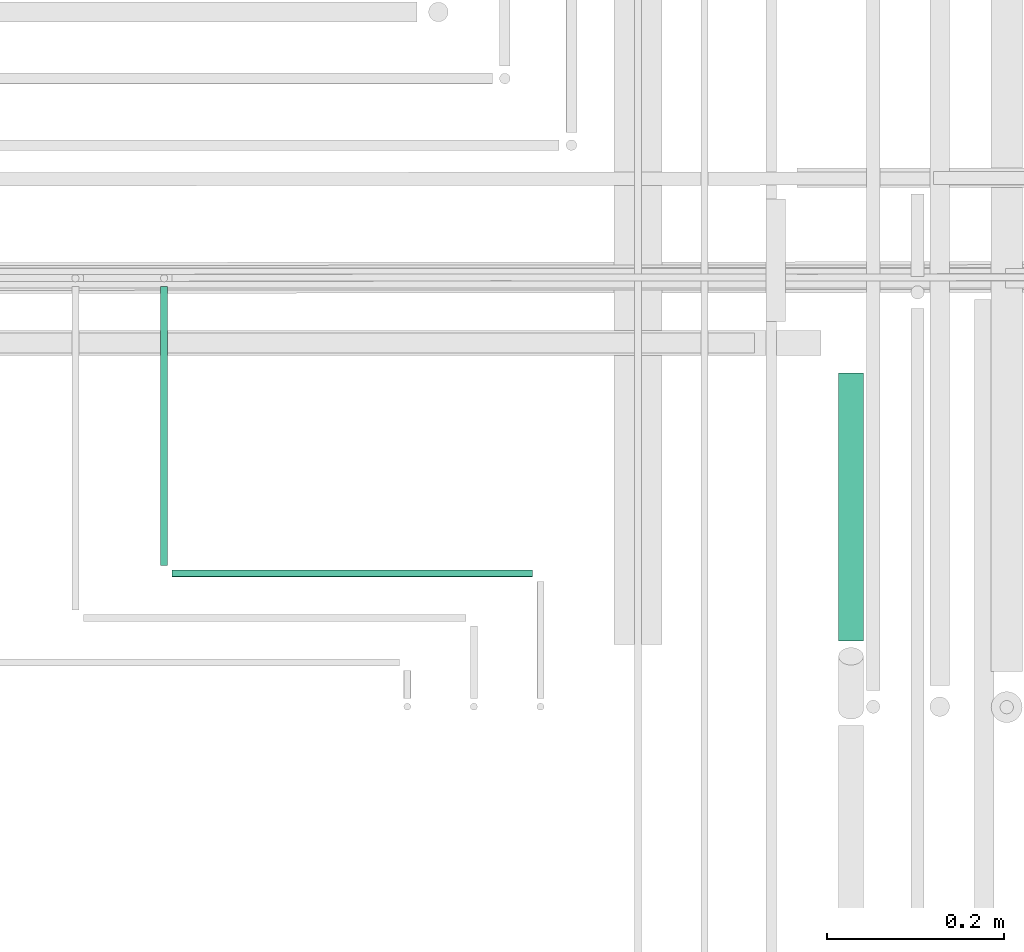
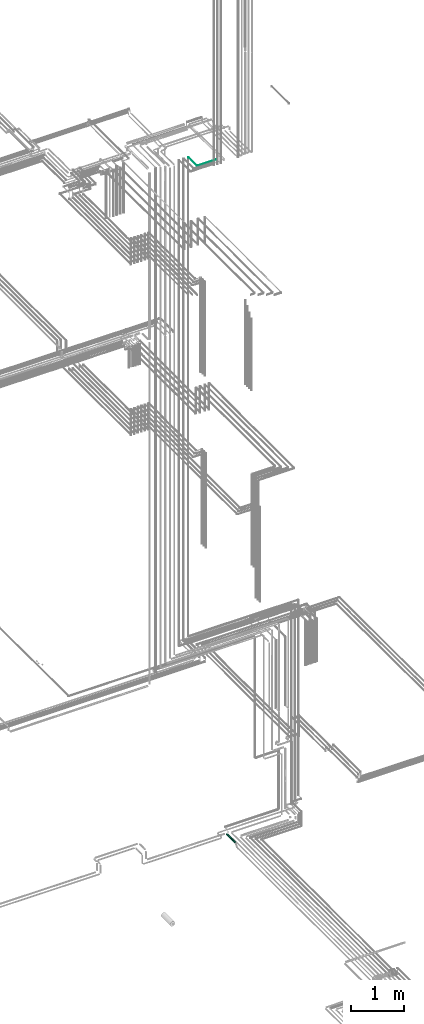
# One storey, part 229 of 331: 3 flow segments.
"""IFC2X3 building model written with IfcOpenShell, lengths in millimetres."""

from ifc_helpers import new_model, entity, si_unit, converted_unit, derived_unit, direction, frame, origin, origin_2d_with_axis, place, context, subcontext, project, spatial, circle, extrude, type_object, element, save


model = new_model("IFC2X3")

# Units and contexts
model_context = context("Model", 3, precision=0.01, world=origin(), true_north=direction((6.12303176911189e-17, 1.0)))
body_context = subcontext(model_context, "Body", "Model", "MODEL_VIEW")
ifc_project = project(units=[si_unit("LENGTHUNIT", "METRE", prefix="MILLI"), si_unit("AREAUNIT", "SQUARE_METRE"), si_unit("VOLUMEUNIT", "CUBIC_METRE"), converted_unit("PLANEANGLEUNIT", "DEGREE", entity("IfcRatioMeasure", 0.0174532925199433), si_unit("PLANEANGLEUNIT", "RADIAN"), dimensions=[0, 0, 0, 0, 0, 0, 0]), si_unit("MASSUNIT", "GRAM", prefix="KILO"), derived_unit("MASSDENSITYUNIT", [(si_unit("MASSUNIT", "GRAM", prefix="KILO"), 1), (si_unit("LENGTHUNIT", "METRE"), -3)]), derived_unit("MOMENTOFINERTIAUNIT", [(si_unit("LENGTHUNIT", "METRE"), 4)]), si_unit("TIMEUNIT", "SECOND"), si_unit("FREQUENCYUNIT", "HERTZ"), si_unit("THERMODYNAMICTEMPERATUREUNIT", "DEGREE_CELSIUS"), derived_unit("THERMALTRANSMITTANCEUNIT", [(si_unit("MASSUNIT", "GRAM", prefix="KILO"), 1), (si_unit("THERMODYNAMICTEMPERATUREUNIT", "KELVIN"), -1), (si_unit("TIMEUNIT", "SECOND"), -3)]), derived_unit("VOLUMETRICFLOWRATEUNIT", [(si_unit("LENGTHUNIT", "METRE"), 3), (si_unit("TIMEUNIT", "SECOND"), -1)]), derived_unit("MASSFLOWRATEUNIT", [(si_unit("MASSUNIT", "GRAM", prefix="KILO"), 1), (si_unit("TIMEUNIT", "SECOND"), -1)]), derived_unit("ROTATIONALFREQUENCYUNIT", [(si_unit("TIMEUNIT", "SECOND"), -1)]), si_unit("ELECTRICCURRENTUNIT", "AMPERE"), si_unit("ELECTRICVOLTAGEUNIT", "VOLT"), si_unit("POWERUNIT", "WATT"), si_unit("FORCEUNIT", "NEWTON", prefix="KILO"), si_unit("ILLUMINANCEUNIT", "LUX"), si_unit("LUMINOUSFLUXUNIT", "LUMEN"), si_unit("LUMINOUSINTENSITYUNIT", "CANDELA"), derived_unit("USERDEFINED", [(si_unit("MASSUNIT", "GRAM", prefix="KILO"), -1), (si_unit("LENGTHUNIT", "METRE"), -2), (si_unit("TIMEUNIT", "SECOND"), 3), (si_unit("LUMINOUSFLUXUNIT", "LUMEN"), 1)]), derived_unit("LINEARVELOCITYUNIT", [(si_unit("LENGTHUNIT", "METRE"), 1), (si_unit("TIMEUNIT", "SECOND"), -1)]), si_unit("PRESSUREUNIT", "PASCAL"), derived_unit("USERDEFINED", [(si_unit("LENGTHUNIT", "METRE"), -2), (si_unit("MASSUNIT", "GRAM", prefix="KILO"), 1), (si_unit("TIMEUNIT", "SECOND"), -2)]), derived_unit("LINEARFORCEUNIT", [(si_unit("MASSUNIT", "GRAM", prefix="KILO"), 1), (si_unit("LENGTHUNIT", "METRE"), 1), (si_unit("TIMEUNIT", "SECOND"), -2), (si_unit("LENGTHUNIT", "METRE"), -1)]), derived_unit("PLANARFORCEUNIT", [(si_unit("MASSUNIT", "GRAM", prefix="KILO"), 1), (si_unit("LENGTHUNIT", "METRE"), 1), (si_unit("TIMEUNIT", "SECOND"), -2), (si_unit("LENGTHUNIT", "METRE"), -2)])], contexts=[model_context])

# Site, building, storey
site_placement = place(None, frame((0.0, -0.00077364408347762, 0.0)))
site = spatial("IfcSite", under=ifc_project, at=site_placement, CompositionType="ELEMENT")
building_placement = place(site_placement, origin())
building = spatial("IfcBuilding", under=site, at=building_placement, CompositionType="ELEMENT")
storey_placement = place(building_placement, origin())
storey = spatial("IfcBuildingStorey", under=building, at=storey_placement, CompositionType="ELEMENT", Elevation=0.0)

# Flow segments
pipe_segment_type = type_object("IfcPipeSegmentType", PredefinedType="NOTDEFINED")
flow_segment_1_placement = place(building_placement, frame((65309.516630958, 7739.0, 2759.40472776408)))
element("IfcFlowSegment", 1, at=flow_segment_1_placement, inside=storey, type_object=pipe_segment_type, context=body_context, shape_type="SweptSolid", body=[
    extrude(circle(Radius=14.0, at=origin_2d_with_axis()), frame((15.5952722359127, 0.0, 15.595272235916), z_axis=(0.0, 1.0, 0.0), x_axis=(-1.0, 0.0, 0.0)), (0.0, 0.0, 1.0), 302.000000000027),
])
flow_segment_2_placement = place(storey_placement, frame((64545.5166110417, 7824.14924977608, 18444.4047277641)))
element("IfcFlowSegment", 2, at=flow_segment_2_placement, inside=storey, type_object=pipe_segment_type, context=body_context, shape_type="SweptSolid", body=[
    extrude(circle(Radius=4.0, at=origin_2d_with_axis()), frame((5.59527223591499, 0.0, 5.59527223591499), z_axis=(0.0, 1.0, 0.0), x_axis=(-1.0, 0.0, 0.0)), (0.0, 0.0, 1.0), 314.780592391817),
])
flow_segment_3_placement = place(storey_placement, frame((64560.1118832776, 7809.55397754016, 18444.4047277641)))
element("IfcFlowSegment", 3, at=flow_segment_3_placement, inside=storey, type_object=pipe_segment_type, context=body_context, shape_type="SweptSolid", body=[
    extrude(circle(Radius=4.0, at=origin_2d_with_axis()), frame((0.0, 5.59527223591607, 5.59527223591499), z_axis=(1.0, 0.0, 0.0), x_axis=(0.0, -1.0, 0.0)), (0.0, 0.0, 1.0), 406.000000000038),
])

save(model, "model.ifc")
